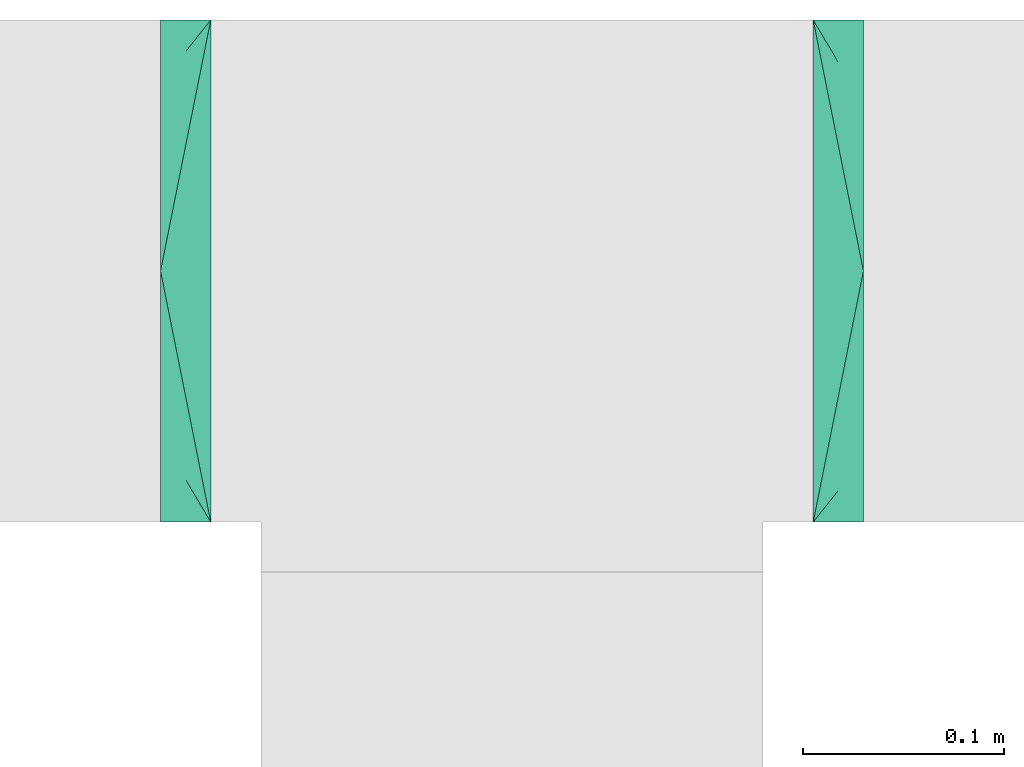
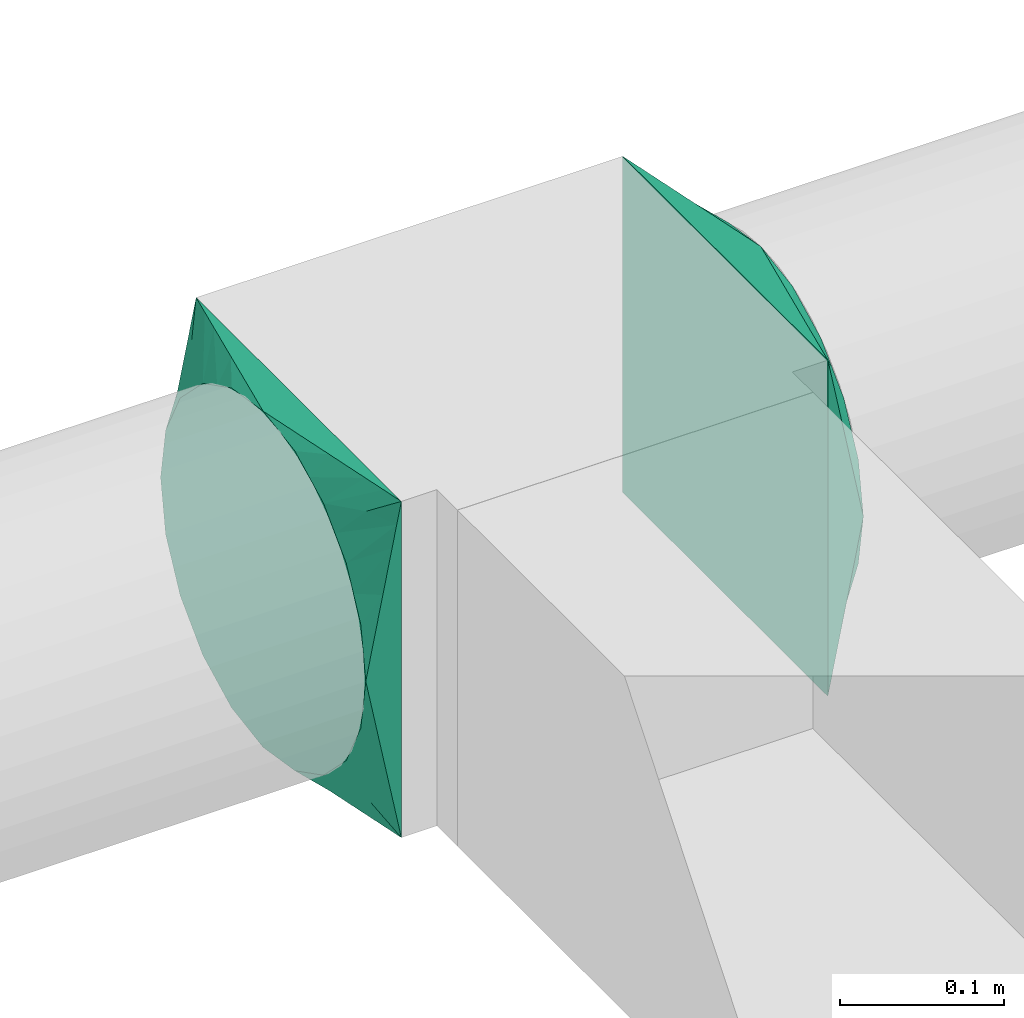
# One storey, part 2 of 3: 2 flow fittings.
"""IFC2X3 building model written with IfcOpenShell, lengths in millimetres."""

from ifc_helpers import new_model, entity, si_unit, converted_unit, derived_unit, direction, frame, origin, place, context, subcontext, project, spatial, faceted_brep, source, transform, mapped, material, type_object, type_shapes, element, save


model = new_model("IFC2X3")

# Units and contexts
model_context = context("Model", 3, precision=0.01, world=origin(), true_north=direction((6.12303176911189e-17, 1.0)))
body_context = subcontext(model_context, "Body", "Model", "MODEL_VIEW")
ifc_project = project(units=[si_unit("LENGTHUNIT", "METRE", prefix="MILLI"), si_unit("AREAUNIT", "SQUARE_METRE"), si_unit("VOLUMEUNIT", "CUBIC_METRE"), converted_unit("PLANEANGLEUNIT", "DEGREE", entity("IfcRatioMeasure", 0.0174532925199433), si_unit("PLANEANGLEUNIT", "RADIAN"), dimensions=[0, 0, 0, 0, 0, 0, 0]), si_unit("MASSUNIT", "GRAM", prefix="KILO"), derived_unit("MASSDENSITYUNIT", [(si_unit("MASSUNIT", "GRAM", prefix="KILO"), 1), (si_unit("LENGTHUNIT", "METRE"), -3)]), si_unit("TIMEUNIT", "SECOND"), si_unit("FREQUENCYUNIT", "HERTZ"), si_unit("THERMODYNAMICTEMPERATUREUNIT", "DEGREE_CELSIUS"), derived_unit("THERMALTRANSMITTANCEUNIT", [(si_unit("MASSUNIT", "GRAM", prefix="KILO"), 1), (si_unit("THERMODYNAMICTEMPERATUREUNIT", "KELVIN"), -1), (si_unit("TIMEUNIT", "SECOND"), -3)]), derived_unit("VOLUMETRICFLOWRATEUNIT", [(si_unit("LENGTHUNIT", "METRE"), 3), (si_unit("TIMEUNIT", "SECOND"), -1)]), si_unit("ELECTRICCURRENTUNIT", "AMPERE"), si_unit("ELECTRICVOLTAGEUNIT", "VOLT"), si_unit("POWERUNIT", "WATT"), si_unit("FORCEUNIT", "NEWTON", prefix="KILO"), si_unit("ILLUMINANCEUNIT", "LUX"), si_unit("LUMINOUSFLUXUNIT", "LUMEN"), si_unit("LUMINOUSINTENSITYUNIT", "CANDELA"), derived_unit("USERDEFINED", [(si_unit("MASSUNIT", "GRAM", prefix="KILO"), -1), (si_unit("LENGTHUNIT", "METRE"), -2), (si_unit("TIMEUNIT", "SECOND"), 3), (si_unit("LUMINOUSFLUXUNIT", "LUMEN"), 1)]), derived_unit("LINEARVELOCITYUNIT", [(si_unit("LENGTHUNIT", "METRE"), 1), (si_unit("TIMEUNIT", "SECOND"), -1)]), si_unit("PRESSUREUNIT", "PASCAL"), derived_unit("USERDEFINED", [(si_unit("LENGTHUNIT", "METRE"), -2), (si_unit("MASSUNIT", "GRAM", prefix="KILO"), 1), (si_unit("TIMEUNIT", "SECOND"), -2)])], contexts=[model_context])

# Site, building, storey
site_placement = place(None, origin())
site = spatial("IfcSite", under=ifc_project, at=site_placement, CompositionType="ELEMENT")
building_placement = place(site_placement, origin())
building = spatial("IfcBuilding", under=site, at=building_placement, CompositionType="ELEMENT")
storey_placement = place(building_placement, frame((0.0, 0.0, 4000.0)))
storey = spatial("IfcBuildingStorey", under=building, at=storey_placement, Name="01 Level", CompositionType="ELEMENT", Elevation=4000.0)

# Flow fittings
ifc_material = material(Name="Material_Duct")
duct_fitting_type = type_object("IfcDuctFittingType", Name="Air_Multi shape transition_Circ", PredefinedType="NOTDEFINED", material=ifc_material)
shared_shape = source(origin(), body_context, "Body", "Brep", [
    faceted_brep([(25.0, 38.627124296869, -118.882064536893), (25.0, 56.0501404167142, -110.00459441688), (25.0, 73.4731565365595, -101.127124296867), (25.0, 87.3001404167141, -87.3001404167125), (25.0, 101.127124296869, -73.4731565365578), (25.0, 110.004594416882, -56.0501404167124), (25.0, 118.882064536894, -38.6271242968671), (25.0, 121.223496625785, -23.8439038991246), (25.0, 123.111748312892, -11.9219519495616), (25.0, 124.055874156446, -5.96097597478013), (25.0, 125.0, 0.0), (25.0, 124.055874155635, 5.96097597990369), (25.0, 123.11174831127, 11.9219519598073), (25.0, 121.22349662254, 23.8439039196147), (25.0, 118.882064536894, 38.6271242968685), (25.0, 110.004594416881, 56.0501404167139), (25.0, 101.127124296868, 73.4731565365593), (25.0, 87.3001404167137, 87.3001404167139), (25.0, 73.473156536559, 101.127124296869), (25.0, 56.0501404167136, 110.004594416881), (25.0, 38.6271242968682, 118.882064536894), (25.0, 23.8439038991258, 121.223496625785), (25.0, 11.9219519495628, 123.111748312892), (25.0, 5.96097597478125, 124.055874156446), (25.0, 0.0, 125.0), (25.0, -5.96097597990388, 124.055874155635), (25.0, -11.9219519598075, 123.11174831127), (25.0, -23.8439039196148, 121.22349662254), (25.0, -38.6271242968687, 118.882064536894), (25.0, -56.050140416714, 110.004594416881), (25.0, -73.4731565365594, 101.127124296868), (25.0, -87.300140416714, 87.3001404167136), (25.0, -101.127124296869, 73.4731565365589), (25.0, -110.004594416881, 56.0501404167135), (25.0, -118.882064536894, 38.6271242968681), (25.0, -121.223496625785, 23.8439038991257), (25.0, -123.111748312893, 11.9219519495627), (25.0, -124.055874156446, 5.96097597478117), (25.0, -125.0, 0.0), (25.0, -124.055874155635, -5.96097597990274), (25.0, -123.11174831127, -11.9219519598064), (25.0, -121.22349662254, -23.8439039196137), (25.0, -118.882064536894, -38.6271242968675), (25.0, -110.004594416881, -56.0501404167129), (25.0, -101.127124296868, -73.4731565365583), (25.0, -87.3001404167137, -87.3001404167129), (25.0, -73.4731565365591, -101.127124296868), (25.0, -56.0501404167137, -110.00459441688), (25.0, -38.6271242968683, -118.882064536893), (25.0, -23.8439038991258, -121.223496625784), (25.0, -11.9219519495628, -123.111748312892), (25.0, -5.9609759747813, -124.055874156445), (25.0, 0.0, -125.0), (25.0, 5.96097597990422, -124.055874155634), (25.0, 11.9219519598079, -123.111748311269), (25.0, 23.8439039196152, -121.223496622539), (0.0, -125.0, -125.0), (0.0, -125.0, 125.0), (0.0, 125.0, 125.0), (0.0, 125.0, -125.0), (13.0142783389037, 59.9286083054818, 125.0), (3.25356958472593, 108.732152076371, 125.0), (12.4999999334883, 103.93826768006, 109.288032538106), (16.0107087541778, 44.9464562291113, 125.0), (19.0071391694519, 29.9643041527408, 125.0), (22.0035695847259, 14.9821520763703, 125.0), (23.501784792363, 7.49107603818503, 125.0), (6.50713897169544, 125.0, 92.464305141524), (3.25356948584772, 125.0, 108.732152570763), (9.76070845754316, 125.0, 76.1964577122852), (13.0142779433909, 125.0, 59.9286102830464), (23.5017847429239, 125.0, 7.49107628538083), (22.0035694858477, 125.0, 14.9821525707616), (19.0071389716954, 125.0, 29.9643051415232), (16.0107084575432, 125.0, 44.9464577122848), (6.50713916945185, 92.4643041527413, 125.0), (9.76070875417778, 76.1964562291116, 125.0), (23.501784792363, 125.0, -7.49107603818391), (22.0035695847259, 125.0, -14.9821520763692), (19.0071391694518, 125.0, -29.9643041527398), (16.0107087541778, 125.0, -44.9464562291103), (13.0142783389037, 125.0, -59.9286083054808), (9.76070875417777, 125.0, -76.1964562291106), (6.50713916945185, 125.0, -92.4643041527404), (3.25356958472592, 125.0, -108.73215207637), (12.4999999334883, 109.288032538106, -103.938267680059), (6.50713897169543, 92.4643051415237, -125.0), (3.25356948584772, 108.732152570762, -125.0), (9.76070845754315, 76.196457712285, -125.0), (13.0142779433909, 59.9286102830464, -125.0), (23.5017847429239, 7.49107628538129, -125.0), (22.0035694858477, 14.982152570762, -125.0), (19.0071389716954, 29.9643051415235, -125.0), (16.0107084575431, 44.9464577122849, -125.0), (23.501784792363, -7.49107603818498, -125.0), (22.0035695847259, -14.9821520763701, -125.0), (19.0071391694519, -29.9643041527404, -125.0), (16.0107087541778, -44.9464562291108, -125.0), (13.0142783389037, -59.9286083054811, -125.0), (9.76070875417778, -76.1964562291107, -125.0), (6.50713916945185, -92.4643041527402, -125.0), (3.25356958472593, -108.73215207637, -125.0), (12.4999999334883, -103.938267680059, -109.288032538105), (6.50713897169544, -125.0, -92.4643051415225), (3.25356948584772, -125.0, -108.732152570761), (9.76070845754316, -125.0, -76.1964577122838), (13.0142779433909, -125.0, -59.9286102830451), (23.5017847429239, -125.0, -7.49107628537984), (22.0035694858477, -125.0, -14.9821525707606), (19.0071389716954, -125.0, -29.9643051415221), (16.0107084575432, -125.0, -44.9464577122836), (23.501784792363, -125.0, 7.49107603818499), (22.0035695847259, -125.0, 14.9821520763703), (19.0071391694519, -125.0, 29.9643041527409), (16.0107087541778, -125.0, 44.9464562291115), (13.0142783389037, -125.0, 59.9286083054821), (9.76070875417777, -125.0, 76.196456229112), (6.50713916945185, -125.0, 92.4643041527418), (3.25356958472593, -125.0, 108.732152076372), (12.4999999334883, -109.288032538105, 103.93826768006), (6.50713897169544, -92.4643051415224, 125.0), (3.25356948584772, -108.732152570761, 125.0), (9.76070845754316, -76.1964577122839, 125.0), (13.0142779433909, -59.9286102830454, 125.0), (23.5017847429239, -7.49107628538088, 125.0), (22.0035694858477, -14.9821525707615, 125.0), (19.0071389716954, -29.9643051415228, 125.0), (16.0107084575432, -44.9464577122841, 125.0)], [[[0, 1, 2, 3, 4, 5, 6, 7, 8, 9, 10, 11, 12, 13, 14, 15, 16, 17, 18, 19, 20, 21, 22, 23, 24, 25, 26, 27, 28, 29, 30, 31, 32, 33, 34, 35, 36, 37, 38, 39, 40, 41, 42, 43, 44, 45, 46, 47, 48, 49, 50, 51, 52, 53, 54, 55]], [[56, 57, 58, 59]], [[20, 19, 60]], [[61, 62, 58]], [[60, 63, 64, 65, 66, 24, 23, 22, 21, 20]], [[67, 68, 16]], [[18, 62, 61]], [[69, 67, 15, 70]], [[13, 12, 11, 10, 71, 72, 73, 74, 70, 14]], [[19, 18, 75]], [[76, 60, 19, 75]], [[15, 14, 70]], [[17, 68, 62]], [[61, 75, 18]], [[17, 16, 68]], [[17, 62, 18]], [[68, 58, 62]], [[16, 15, 67]], [[77, 78, 79, 80, 81, 82, 83, 84, 59, 58, 68, 67, 69, 70, 74, 73, 72, 71, 10]], [[6, 5, 81]], [[84, 85, 59]], [[81, 80, 79, 78, 77, 10, 9, 8, 7, 6]], [[86, 87, 2]], [[4, 85, 84]], [[88, 86, 1, 89]], [[55, 54, 53, 52, 90, 91, 92, 93, 89, 0]], [[5, 4, 83]], [[82, 81, 5, 83]], [[1, 0, 89]], [[3, 87, 85]], [[84, 83, 4]], [[3, 2, 87]], [[3, 85, 4]], [[87, 59, 85]], [[2, 1, 86]], [[56, 59, 87, 86, 88, 89, 93, 92, 91, 90, 52, 94, 95, 96, 97, 98, 99, 100, 101]], [[48, 47, 98]], [[101, 102, 56]], [[98, 97, 96, 95, 94, 52, 51, 50, 49, 48]], [[103, 104, 44]], [[46, 102, 101]], [[105, 103, 43, 106]], [[41, 40, 39, 38, 107, 108, 109, 110, 106, 42]], [[47, 46, 100]], [[99, 98, 47, 100]], [[43, 42, 106]], [[45, 104, 102]], [[101, 100, 46]], [[45, 44, 104]], [[45, 102, 46]], [[104, 56, 102]], [[44, 43, 103]], [[111, 112, 113, 114, 115, 116, 117, 118, 57, 56, 104, 103, 105, 106, 110, 109, 108, 107, 38]], [[34, 33, 115]], [[118, 119, 57]], [[115, 114, 113, 112, 111, 38, 37, 36, 35, 34]], [[120, 121, 30]], [[32, 119, 118]], [[122, 120, 29, 123]], [[27, 26, 25, 24, 124, 125, 126, 127, 123, 28]], [[33, 32, 117]], [[116, 115, 33, 117]], [[29, 28, 123]], [[31, 121, 119]], [[118, 117, 32]], [[31, 30, 121]], [[31, 119, 32]], [[121, 57, 119]], [[30, 29, 120]], [[66, 65, 64, 63, 60, 76, 75, 61, 58, 57, 121, 120, 122, 123, 127, 126, 125, 124, 24]]]),
])
type_shapes(duct_fitting_type, [shared_shape])
flow_fitting_1_placement = place(storey_placement, frame((24480.6615179764, -63810.5772743263, 3510.0), z_axis=(0.0, 0.0, 1.0), x_axis=(-1.0, 0.0, 0.0)))
element("IfcFlowFitting", 1, at=flow_fitting_1_placement, inside=storey, type_object=duct_fitting_type, material=ifc_material, Name="multi_shape_trans_001:Air_Multi shape transition_Circ", ObjectType="multi_shape_trans_001:Air_Multi shape transition_Circ", context=body_context, shape_type="MappedRepresentation", body=[
    mapped(shared_shape, transform((0.0, 0.0, 0.0), scale=1.0)),
])
flow_fitting_2_placement = place(storey_placement, frame((24780.6615179764, -63810.5772743263, 3510.0)))
element("IfcFlowFitting", 2, at=flow_fitting_2_placement, inside=storey, type_object=duct_fitting_type, material=ifc_material, Name="multi_shape_trans_001:Air_Multi shape transition_Circ", ObjectType="multi_shape_trans_001:Air_Multi shape transition_Circ", context=body_context, shape_type="MappedRepresentation", body=[
    mapped(shared_shape, transform((0.0, 0.0, 0.0), scale=1.0)),
])

save(model, "model.ifc")
